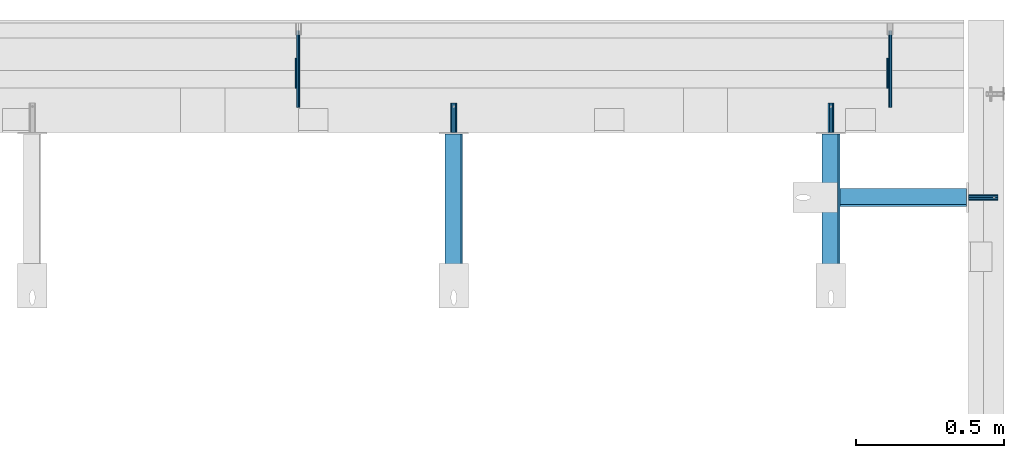
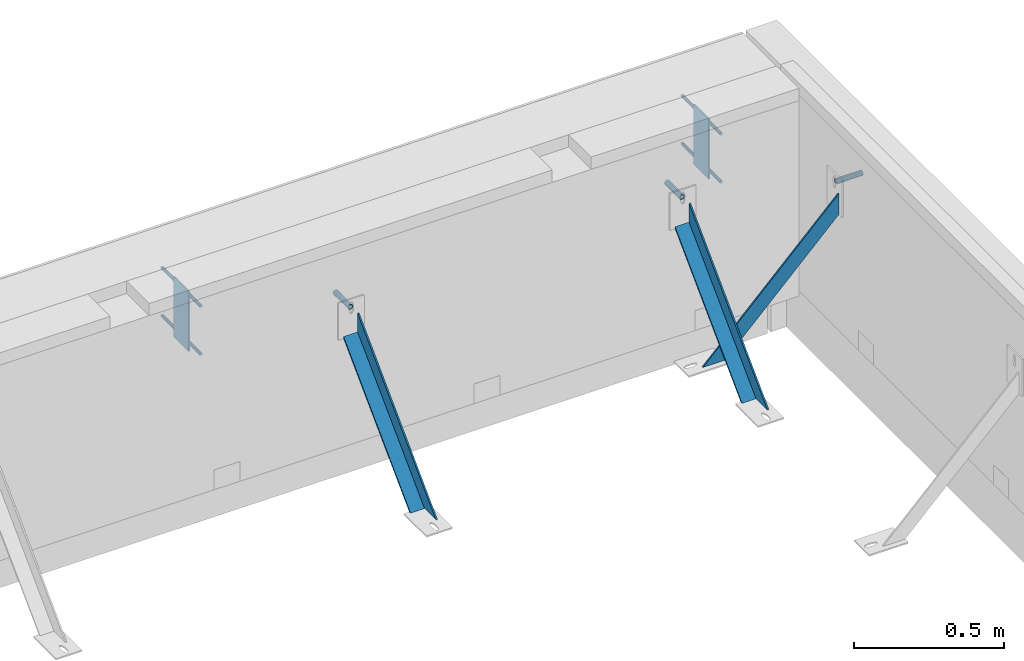
# One storey, part 58 of 153: 9 beams, 3 members, 14 elements without a shape of their own.
"""IFC2X3 building model written with IfcOpenShell, lengths in millimetres."""

from ifc_helpers import new_model, si_unit, frame, origin_with_axes, place, context, subcontext, project, spatial, faceted_brep, material, type_object, element, aggregate, save


model = new_model("IFC2X3")

# Units and contexts
model_context = context("Model", 3, precision=1e-05, world=origin_with_axes())
body_context = subcontext(model_context, "Body", "Model", "MODEL_VIEW")
ifc_project = project(units=[si_unit("LENGTHUNIT", "METRE", prefix="MILLI"), si_unit("AREAUNIT", "SQUARE_METRE"), si_unit("VOLUMEUNIT", "CUBIC_METRE"), si_unit("MASSUNIT", "GRAM", prefix="KILO"), si_unit("TIMEUNIT", "SECOND"), si_unit("PLANEANGLEUNIT", "RADIAN"), si_unit("SOLIDANGLEUNIT", "STERADIAN"), si_unit("THERMODYNAMICTEMPERATUREUNIT", "DEGREE_CELSIUS"), si_unit("LUMINOUSINTENSITYUNIT", "LUMEN")], contexts=[model_context])

# Site, building, storey
site_placement = place(None, origin_with_axes())
site = spatial("IfcSite", under=ifc_project, at=site_placement, CompositionType="ELEMENT")
building_placement = place(site_placement, origin_with_axes())
building = spatial("IfcBuilding", under=site, at=building_placement, CompositionType="ELEMENT")
storey_placement = place(building_placement, origin_with_axes())
storey = spatial("IfcBuildingStorey", under=building, at=storey_placement, Name="8", CompositionType="ELEMENT", Elevation=0.0)

# Assemblies, beam
assembly_1_placement = place(storey_placement, origin_with_axes())
assembly_1 = element("IfcElementAssembly", 1, at=assembly_1_placement, inside=storey, AssemblyPlace="NOTDEFINED", PredefinedType="REINFORCEMENT_UNIT")
assembly_2_placement = place(assembly_1_placement, origin_with_axes())
assembly_2 = element("IfcElementAssembly", 2, at=assembly_2_placement, Name="Steel Assembly", AssemblyPlace="NOTDEFINED", PredefinedType="RIGID_FRAME")
aggregate(assembly_1, [assembly_2])
ifc_material_1 = material(Name="STEEL/Steel_Undefined")
beam_type_1 = type_object("IfcBeamType", PredefinedType="NOTDEFINED")
beam_1_placement = place(assembly_2_placement, frame((35244.9969543136, 22400.0099999998, 103320.0), z_axis=(0.0, 1.0, 0.0), x_axis=(1.0, 0.0, 0.0)))
beam_1 = element("IfcBeam", 3, at=beam_1_placement, type_object=beam_type_1, material=ifc_material_1, Name="1036-G", context=body_context, shape_type="Brep", body=[
    faceted_brep([(0.0, -8.49999999999272, -1.45519152283669e-11), (0.0, -7.36121593215648, 4.24999999998545), (100.000000000262, -7.36121593215648, 4.24999999998545), (100.000000000262, -8.49999999999272, -1.45519152283669e-11), (0.0, -4.24999999998545, 7.36121593216376), (100.000000000262, -4.24999999998545, 7.36121593216376), (0.0, 1.45519152283669e-11, 8.49999999998545), (100.000000000262, 1.45519152283669e-11, 8.49999999998545), (0.0, 4.25000000001455, 7.36121593216376), (100.000000000262, 4.25000000001455, 7.36121593216376), (0.0, 7.36121593217104, 4.24999999998545), (100.000000000262, 7.36121593217104, 4.24999999998545), (0.0, 8.50000000000728, 0.0), (100.000000000262, 8.50000000000728, 0.0), (0.0, 7.36121593217104, -4.25000000001455), (100.000000000262, 7.36121593217104, -4.25000000001455), (0.0, 4.25000000000728, -7.36121593219286), (100.000000000262, 4.25000000000728, -7.36121593219286), (0.0, 7.27595761418343e-12, -8.5), (100.000000000262, 7.27595761418343e-12, -8.5), (0.0, -4.24999999999272, -7.36121593217831), (100.000000000262, -4.24999999999272, -7.36121593217831), (0.0, -7.36121593215648, -4.25), (100.000000000262, -7.36121593215648, -4.25), (0.0, -10.4999999999927, -1.45519152283669e-11), (0.0, -9.09326673972828, -5.25000000001455), (100.000000000262, -9.09326673972828, -5.25000000001455), (100.000000000262, -10.4999999999927, -1.45519152283669e-11), (0.0, -5.24999999998545, -9.09326673974283), (100.000000000262, -5.24999999998545, -9.09326673974283), (0.0, 7.27595761418343e-12, -10.5), (100.000000000262, 7.27595761418343e-12, -10.5), (0.0, 5.25000000001455, -9.09326673975738), (100.000000000262, 5.25000000001455, -9.09326673975738), (0.0, 9.09326673975011, -5.25000000001455), (100.000000000262, 9.09326673975011, -5.25000000001455), (0.0, 10.5000000000073, -1.45519152283669e-11), (100.000000000262, 10.5000000000073, -1.45519152283669e-11), (0.0, 9.09326673975011, 5.25), (100.000000000262, 9.09326673975011, 5.25), (0.0, 5.25000000000728, 9.09326673972828), (100.000000000262, 5.25000000000728, 9.09326673972828), (0.0, 1.45519152283669e-11, 10.4999999999854), (100.000000000262, 1.45519152283669e-11, 10.4999999999854), (0.0, -5.24999999999272, 9.09326673972828), (100.000000000262, -5.24999999999272, 9.09326673972828), (0.0, -9.09326673972828, 5.24999999998545), (100.000000000262, -9.09326673972828, 5.24999999998545)], [[[0, 1, 2, 3]], [[1, 4, 5, 2]], [[4, 6, 7, 5]], [[6, 8, 9, 7]], [[8, 10, 11, 9]], [[10, 12, 13, 11]], [[12, 14, 15, 13]], [[14, 16, 17, 15]], [[16, 18, 19, 17]], [[18, 20, 21, 19]], [[20, 22, 23, 21]], [[22, 0, 3, 23]], [[24, 25, 26, 27]], [[25, 28, 29, 26]], [[28, 30, 31, 29]], [[30, 32, 33, 31]], [[32, 34, 35, 33]], [[34, 36, 37, 35]], [[36, 38, 39, 37]], [[38, 40, 41, 39]], [[40, 42, 43, 41]], [[42, 44, 45, 43]], [[44, 46, 47, 45]], [[46, 24, 27, 47]], [[29, 31, 33, 35, 37, 39, 41, 43, 45, 47, 27, 26], [5, 7, 9, 11, 13, 15, 17, 19, 21, 23, 3, 2]], [[46, 44, 42, 40, 38, 36, 34, 32, 30, 28, 25, 24], [22, 20, 18, 16, 14, 12, 10, 8, 6, 4, 1, 0]]]),
])
aggregate(assembly_2, [beam_1])

# Assemblies, beams
assembly_3_placement = place(storey_placement, origin_with_axes())
assembly_3 = element("IfcElementAssembly", 4, at=assembly_3_placement, inside=storey, AssemblyPlace="NOTDEFINED", PredefinedType="REINFORCEMENT_UNIT")
assembly_4_placement = place(assembly_3_placement, origin_with_axes())
assembly_4 = element("IfcElementAssembly", 5, at=assembly_4_placement, Name="Steel Assembly", AssemblyPlace="NOTDEFINED", PredefinedType="RIGID_FRAME")
beam_2_placement = place(assembly_4_placement, frame((34779.9964000166, 22619.9999999999, 103285.0), z_axis=(-1.0, 3.00000001838171e-08, 0.0), x_axis=(0.0, 1.0, 0.0)))
beam_2 = element("IfcBeam", 6, at=beam_2_placement, type_object=beam_type_1, material=ifc_material_1, Name="1036-G", context=body_context, shape_type="Brep", body=[
    faceted_brep([(0.0, -8.49999999999272, -1.45519152283669e-11), (0.0, -7.36121593215648, 4.24999999998545), (100.000000000262, -7.36121593215648, 4.24999999998545), (100.000000000262, -8.49999999999272, -1.45519152283669e-11), (0.0, -4.24999999998545, 7.36121593216376), (100.000000000262, -4.24999999998545, 7.36121593216376), (0.0, 1.45519152283669e-11, 8.49999999998545), (100.000000000262, 1.45519152283669e-11, 8.49999999998545), (0.0, 4.25000000001455, 7.36121593216376), (100.000000000262, 4.25000000001455, 7.36121593216376), (0.0, 7.36121593217104, 4.24999999998545), (100.000000000262, 7.36121593217104, 4.24999999998545), (0.0, 8.50000000000728, 0.0), (100.000000000262, 8.50000000000728, 0.0), (0.0, 7.36121593217104, -4.25000000001455), (100.000000000262, 7.36121593217104, -4.25000000001455), (0.0, 4.25000000000728, -7.36121593219286), (100.000000000262, 4.25000000000728, -7.36121593219286), (0.0, 7.27595761418343e-12, -8.5), (100.000000000262, 7.27595761418343e-12, -8.5), (0.0, -4.24999999999272, -7.36121593217831), (100.000000000262, -4.24999999999272, -7.36121593217831), (0.0, -7.36121593215648, -4.25), (100.000000000262, -7.36121593215648, -4.25), (0.0, -10.4999999999927, -1.45519152283669e-11), (0.0, -9.09326673972828, -5.25000000001455), (100.000000000262, -9.09326673972828, -5.25000000001455), (100.000000000262, -10.4999999999927, -1.45519152283669e-11), (0.0, -5.24999999998545, -9.09326673974283), (100.000000000262, -5.24999999998545, -9.09326673974283), (0.0, 7.27595761418343e-12, -10.5), (100.000000000262, 7.27595761418343e-12, -10.5), (0.0, 5.25000000001455, -9.09326673975738), (100.000000000262, 5.25000000001455, -9.09326673975738), (0.0, 9.09326673975011, -5.25000000001455), (100.000000000262, 9.09326673975011, -5.25000000001455), (0.0, 10.5000000000073, -1.45519152283669e-11), (100.000000000262, 10.5000000000073, -1.45519152283669e-11), (0.0, 9.09326673975011, 5.25), (100.000000000262, 9.09326673975011, 5.25), (0.0, 5.25000000000728, 9.09326673972828), (100.000000000262, 5.25000000000728, 9.09326673972828), (0.0, 1.45519152283669e-11, 10.4999999999854), (100.000000000262, 1.45519152283669e-11, 10.4999999999854), (0.0, -5.24999999999272, 9.09326673972828), (100.000000000262, -5.24999999999272, 9.09326673972828), (0.0, -9.09326673972828, 5.24999999998545), (100.000000000262, -9.09326673972828, 5.24999999998545)], [[[0, 1, 2, 3]], [[1, 4, 5, 2]], [[4, 6, 7, 5]], [[6, 8, 9, 7]], [[8, 10, 11, 9]], [[10, 12, 13, 11]], [[12, 14, 15, 13]], [[14, 16, 17, 15]], [[16, 18, 19, 17]], [[18, 20, 21, 19]], [[20, 22, 23, 21]], [[22, 0, 3, 23]], [[24, 25, 26, 27]], [[25, 28, 29, 26]], [[28, 30, 31, 29]], [[30, 32, 33, 31]], [[32, 34, 35, 33]], [[34, 36, 37, 35]], [[36, 38, 39, 37]], [[38, 40, 41, 39]], [[40, 42, 43, 41]], [[42, 44, 45, 43]], [[44, 46, 47, 45]], [[46, 24, 27, 47]], [[29, 31, 33, 35, 37, 39, 41, 43, 45, 47, 27, 26], [5, 7, 9, 11, 13, 15, 17, 19, 21, 23, 3, 2]], [[46, 44, 42, 40, 38, 36, 34, 32, 30, 28, 25, 24], [22, 20, 18, 16, 14, 12, 10, 8, 6, 4, 1, 0]]]),
])
aggregate(assembly_4, [beam_2])
assembly_5_placement = place(assembly_3_placement, origin_with_axes())
assembly_5 = element("IfcElementAssembly", 7, at=assembly_5_placement, Name="Steel Assembly", AssemblyPlace="NOTDEFINED", PredefinedType="RIGID_FRAME")
beam_3_placement = place(assembly_5_placement, frame((33504.9999728033, 22619.9999999999, 103285.0), z_axis=(-1.0, 3.00000001838171e-08, 0.0), x_axis=(0.0, 1.0, 0.0)))
beam_3 = element("IfcBeam", 8, at=beam_3_placement, type_object=beam_type_1, material=ifc_material_1, Name="1036-G", context=body_context, shape_type="Brep", body=[
    faceted_brep([(0.0, -8.49999999999272, -1.45519152283669e-11), (0.0, -7.36121593215648, 4.24999999998545), (100.000000000262, -7.36121593215648, 4.24999999998545), (100.000000000262, -8.49999999999272, -1.45519152283669e-11), (0.0, -4.24999999998545, 7.36121593216376), (100.000000000262, -4.24999999998545, 7.36121593216376), (0.0, 1.45519152283669e-11, 8.49999999998545), (100.000000000262, 1.45519152283669e-11, 8.49999999998545), (0.0, 4.25000000001455, 7.36121593216376), (100.000000000262, 4.25000000001455, 7.36121593216376), (0.0, 7.36121593217104, 4.24999999998545), (100.000000000262, 7.36121593217104, 4.24999999998545), (0.0, 8.50000000000728, 0.0), (100.000000000262, 8.50000000000728, 0.0), (0.0, 7.36121593217104, -4.25000000001455), (100.000000000262, 7.36121593217104, -4.25000000001455), (0.0, 4.25000000000728, -7.36121593219286), (100.000000000262, 4.25000000000728, -7.36121593219286), (0.0, 7.27595761418343e-12, -8.5), (100.000000000262, 7.27595761418343e-12, -8.5), (0.0, -4.24999999999272, -7.36121593217831), (100.000000000262, -4.24999999999272, -7.36121593217831), (0.0, -7.36121593215648, -4.25), (100.000000000262, -7.36121593215648, -4.25), (0.0, -10.4999999999927, -1.45519152283669e-11), (0.0, -9.09326673972828, -5.25000000001455), (100.000000000262, -9.09326673972828, -5.25000000001455), (100.000000000262, -10.4999999999927, -1.45519152283669e-11), (0.0, -5.24999999998545, -9.09326673974283), (100.000000000262, -5.24999999998545, -9.09326673974283), (0.0, 7.27595761418343e-12, -10.5), (100.000000000262, 7.27595761418343e-12, -10.5), (0.0, 5.25000000001455, -9.09326673975738), (100.000000000262, 5.25000000001455, -9.09326673975738), (0.0, 9.09326673975011, -5.25000000001455), (100.000000000262, 9.09326673975011, -5.25000000001455), (0.0, 10.5000000000073, -1.45519152283669e-11), (100.000000000262, 10.5000000000073, -1.45519152283669e-11), (0.0, 9.09326673975011, 5.25), (100.000000000262, 9.09326673975011, 5.25), (0.0, 5.25000000000728, 9.09326673972828), (100.000000000262, 5.25000000000728, 9.09326673972828), (0.0, 1.45519152283669e-11, 10.4999999999854), (100.000000000262, 1.45519152283669e-11, 10.4999999999854), (0.0, -5.24999999999272, 9.09326673972828), (100.000000000262, -5.24999999999272, 9.09326673972828), (0.0, -9.09326673972828, 5.24999999998545), (100.000000000262, -9.09326673972828, 5.24999999998545)], [[[0, 1, 2, 3]], [[1, 4, 5, 2]], [[4, 6, 7, 5]], [[6, 8, 9, 7]], [[8, 10, 11, 9]], [[10, 12, 13, 11]], [[12, 14, 15, 13]], [[14, 16, 17, 15]], [[16, 18, 19, 17]], [[18, 20, 21, 19]], [[20, 22, 23, 21]], [[22, 0, 3, 23]], [[24, 25, 26, 27]], [[25, 28, 29, 26]], [[28, 30, 31, 29]], [[30, 32, 33, 31]], [[32, 34, 35, 33]], [[34, 36, 37, 35]], [[36, 38, 39, 37]], [[38, 40, 41, 39]], [[40, 42, 43, 41]], [[42, 44, 45, 43]], [[44, 46, 47, 45]], [[46, 24, 27, 47]], [[29, 31, 33, 35, 37, 39, 41, 43, 45, 47, 27, 26], [5, 7, 9, 11, 13, 15, 17, 19, 21, 23, 3, 2]], [[46, 44, 42, 40, 38, 36, 34, 32, 30, 28, 25, 24], [22, 20, 18, 16, 14, 12, 10, 8, 6, 4, 1, 0]]]),
])
aggregate(assembly_5, [beam_3])
assembly_6_placement = place(assembly_3_placement, origin_with_axes())
assembly_6 = element("IfcElementAssembly", 9, at=assembly_6_placement, Name="Steel Assembly", AssemblyPlace="NOTDEFINED", PredefinedType="RIGID_FRAME")
beam_type_2 = type_object("IfcBeamType", Name="D12", PredefinedType="NOTDEFINED")
beam_4_placement = place(assembly_6_placement, frame((32979.9934191889, 22704.9948219476, 103224.99266456), z_axis=(-1.0, 3.00000001838171e-08, 0.0), x_axis=(-1.71000001528888e-07, 0.999999999916793, 1.28990000076059e-05)))
beam_4 = element("IfcBeam", 10, at=beam_4_placement, type_object=beam_type_2, material=ifc_material_1, Name="M12", ObjectType="D12", context=body_context, shape_type="Brep", body=[
    faceted_brep([(0.0, -6.0, -1.45519152283669e-11), (0.0, -4.24264068712, -4.24264068713819), (260.003353918641, -4.24264068710909, -4.24264068711909), (260.003353918641, -6.0, 0.0), (3.63797880709171e-12, 0.0, -6.0000000000291), (260.003353918644, 0.0, -6.0), (0.0, 4.24264068712, -4.24264068713819), (260.003353918641, 4.24264068710909, -4.24264068711909), (0.0, 6.0, -1.45519152283669e-11), (260.003353918644, 6.0, 9.09494701772928e-13), (0.0, 4.24264068712, 4.24264068709454), (260.003353918641, 4.24264068710909, 4.24264068711909), (0.0, 0.0, 5.99999999998545), (260.003353918644, 0.0, 6.0), (0.0, -4.24264068712, 4.24264068709454), (260.003353918641, -4.24264068710909, 4.24264068711909)], [[[0, 1, 2, 3]], [[1, 4, 5, 2]], [[4, 6, 7, 5]], [[6, 8, 9, 7]], [[8, 10, 11, 9]], [[10, 12, 13, 11]], [[12, 14, 15, 13]], [[14, 0, 3, 15]], [[5, 7, 9, 11, 13, 15, 3, 2]], [[14, 12, 10, 8, 6, 4, 1, 0]]]),
])
aggregate(assembly_6, [beam_4])
assembly_7_placement = place(assembly_3_placement, origin_with_axes())
assembly_7 = element("IfcElementAssembly", 11, at=assembly_7_placement, Name="Steel Assembly", AssemblyPlace="NOTDEFINED", PredefinedType="RIGID_FRAME")
beam_5_placement = place(assembly_7_placement, frame((32979.9934191889, 22704.9948219476, 103419.99266456), z_axis=(-1.0, 3.00000001838171e-08, 0.0), x_axis=(-1.71000001528888e-07, 0.999999999916793, 1.28990000076059e-05)))
beam_5 = element("IfcBeam", 12, at=beam_5_placement, type_object=beam_type_2, material=ifc_material_1, Name="M12", ObjectType="D12", context=body_context, shape_type="Brep", body=[
    faceted_brep([(0.0, -6.0, -1.45519152283669e-11), (0.0, -4.24264068712, -4.24264068713819), (260.003353918641, -4.24264068710909, -4.24264068711909), (260.003353918641, -6.0, 0.0), (3.63797880709171e-12, 0.0, -6.0000000000291), (260.003353918644, 0.0, -6.0), (0.0, 4.24264068712, -4.24264068713819), (260.003353918641, 4.24264068710909, -4.24264068711909), (0.0, 6.0, -1.45519152283669e-11), (260.003353918644, 6.0, 9.09494701772928e-13), (0.0, 4.24264068712, 4.24264068709454), (260.003353918641, 4.24264068710909, 4.24264068711909), (0.0, 0.0, 5.99999999998545), (260.003353918644, 0.0, 6.0), (0.0, -4.24264068712, 4.24264068709454), (260.003353918641, -4.24264068710909, 4.24264068711909)], [[[0, 1, 2, 3]], [[1, 4, 5, 2]], [[4, 6, 7, 5]], [[6, 8, 9, 7]], [[8, 10, 11, 9]], [[10, 12, 13, 11]], [[12, 14, 15, 13]], [[14, 0, 3, 15]], [[5, 7, 9, 11, 13, 15, 3, 2]], [[14, 12, 10, 8, 6, 4, 1, 0]]]),
])
aggregate(assembly_7, [beam_5])
assembly_8_placement = place(assembly_3_placement, origin_with_axes())
assembly_8 = element("IfcElementAssembly", 13, at=assembly_8_placement, Name="Steel Assembly", AssemblyPlace="NOTDEFINED", PredefinedType="RIGID_FRAME")
beam_6_placement = place(assembly_8_placement, frame((34979.9934191889, 22704.9948219476, 103224.99266456), z_axis=(-1.0, 3.00000001838171e-08, 0.0), x_axis=(-1.71000001528888e-07, 0.999999999916793, 1.28990000076059e-05)))
beam_6 = element("IfcBeam", 14, at=beam_6_placement, type_object=beam_type_2, material=ifc_material_1, Name="M12", ObjectType="D12", context=body_context, shape_type="Brep", body=[
    faceted_brep([(0.0, -6.0, -1.45519152283669e-11), (0.0, -4.24264068712, -4.24264068713819), (260.003353918641, -4.24264068710909, -4.24264068711909), (260.003353918641, -6.0, 0.0), (3.63797880709171e-12, 0.0, -6.0000000000291), (260.003353918644, 0.0, -6.0), (0.0, 4.24264068712, -4.24264068713819), (260.003353918641, 4.24264068710909, -4.24264068711909), (0.0, 6.0, -1.45519152283669e-11), (260.003353918644, 6.0, 9.09494701772928e-13), (0.0, 4.24264068712, 4.24264068709454), (260.003353918641, 4.24264068710909, 4.24264068711909), (0.0, 0.0, 5.99999999998545), (260.003353918644, 0.0, 6.0), (0.0, -4.24264068712, 4.24264068709454), (260.003353918641, -4.24264068710909, 4.24264068711909)], [[[0, 1, 2, 3]], [[1, 4, 5, 2]], [[4, 6, 7, 5]], [[6, 8, 9, 7]], [[8, 10, 11, 9]], [[10, 12, 13, 11]], [[12, 14, 15, 13]], [[14, 0, 3, 15]], [[5, 7, 9, 11, 13, 15, 3, 2]], [[14, 12, 10, 8, 6, 4, 1, 0]]]),
])
aggregate(assembly_8, [beam_6])
assembly_9_placement = place(assembly_3_placement, origin_with_axes())
assembly_9 = element("IfcElementAssembly", 15, at=assembly_9_placement, Name="Steel Assembly", AssemblyPlace="NOTDEFINED", PredefinedType="RIGID_FRAME")
beam_7_placement = place(assembly_9_placement, frame((34979.9934191889, 22704.9948219476, 103419.99266456), z_axis=(-1.0, 3.00000001838171e-08, 0.0), x_axis=(-1.71000001528888e-07, 0.999999999916793, 1.28990000076059e-05)))
beam_7 = element("IfcBeam", 16, at=beam_7_placement, type_object=beam_type_2, material=ifc_material_1, Name="M12", ObjectType="D12", context=body_context, shape_type="Brep", body=[
    faceted_brep([(0.0, -6.0, -1.45519152283669e-11), (0.0, -4.24264068712, -4.24264068713819), (260.003353918641, -4.24264068710909, -4.24264068711909), (260.003353918641, -6.0, 0.0), (3.63797880709171e-12, 0.0, -6.0000000000291), (260.003353918644, 0.0, -6.0), (0.0, 4.24264068712, -4.24264068713819), (260.003353918641, 4.24264068710909, -4.24264068711909), (0.0, 6.0, -1.45519152283669e-11), (260.003353918644, 6.0, 9.09494701772928e-13), (0.0, 4.24264068712, 4.24264068709454), (260.003353918641, 4.24264068710909, 4.24264068711909), (0.0, 0.0, 5.99999999998545), (260.003353918644, 0.0, 6.0), (0.0, -4.24264068712, 4.24264068709454), (260.003353918641, -4.24264068710909, 4.24264068711909)], [[[0, 1, 2, 3]], [[1, 4, 5, 2]], [[4, 6, 7, 5]], [[6, 8, 9, 7]], [[8, 10, 11, 9]], [[10, 12, 13, 11]], [[12, 14, 15, 13]], [[14, 0, 3, 15]], [[5, 7, 9, 11, 13, 15, 3, 2]], [[14, 12, 10, 8, 6, 4, 1, 0]]]),
])
aggregate(assembly_9, [beam_7])
assembly_10_placement = place(assembly_3_placement, origin_with_axes())
assembly_10 = element("IfcElementAssembly", 17, at=assembly_10_placement, Name="Steel Assembly", AssemblyPlace="NOTDEFINED", PredefinedType="RIGID_FRAME")
ifc_material_2 = material(Name="STEEL/1.4301")
beam_type_3 = type_object("IfcBeamType", PredefinedType="NOTDEFINED")
beam_8_placement = place(assembly_10_placement, frame((32971.494772816, 22819.9981743288, 103444.99266456), z_axis=(0.0, 1.0, 0.0), x_axis=(0.0, 0.0, -1.0)))
beam_8 = element("IfcBeam", 18, at=beam_8_placement, type_object=beam_type_3, material=ifc_material_2, Name="RST", context=body_context, shape_type="Brep", body=[
    faceted_brep([(0.0, 2.5, -49.9999999999964), (0.0, 2.49999999999909, 50.0000000000036), (245.0, 2.49999999999909, 50.0000000000036), (245.0, 2.5, -49.9999999999964), (0.0, -2.50000000000091, 50.0000000000036), (245.0, -2.50000000000091, 50.0000000000036), (0.0, -2.50000000000091, -49.9999999999964), (245.0, -2.50000000000091, -49.9999999999964)], [[[0, 1, 2, 3]], [[1, 4, 5, 2]], [[4, 6, 7, 5]], [[6, 0, 3, 7]], [[5, 7, 3, 2]], [[6, 4, 1, 0]]]),
])
aggregate(assembly_10, [beam_8])
assembly_11_placement = place(assembly_3_placement, origin_with_axes())
assembly_11 = element("IfcElementAssembly", 19, at=assembly_11_placement, Name="Steel Assembly", AssemblyPlace="NOTDEFINED", PredefinedType="RIGID_FRAME")
aggregate(assembly_3, [assembly_4, assembly_5, assembly_6, assembly_10, assembly_7, assembly_8, assembly_11, assembly_9])
beam_9_placement = place(assembly_11_placement, frame((34971.494772816, 22819.9981743288, 103444.99266456), z_axis=(0.0, 1.0, 0.0), x_axis=(0.0, 0.0, -1.0)))
beam_9 = element("IfcBeam", 20, at=beam_9_placement, type_object=beam_type_3, material=ifc_material_2, Name="RST", context=body_context, shape_type="Brep", body=[
    faceted_brep([(0.0, 2.5, -49.9999999999964), (0.0, 2.49999999999909, 50.0000000000036), (245.0, 2.49999999999909, 50.0000000000036), (245.0, 2.5, -49.9999999999964), (0.0, -2.50000000000091, 50.0000000000036), (245.0, -2.50000000000091, 50.0000000000036), (0.0, -2.50000000000091, -49.9999999999964), (245.0, -2.50000000000091, -49.9999999999964)], [[[0, 1, 2, 3]], [[1, 4, 5, 2]], [[4, 6, 7, 5]], [[6, 0, 3, 7]], [[5, 7, 3, 2]], [[6, 4, 1, 0]]]),
])
aggregate(assembly_11, [beam_9])

# Assembly, member
assembly_12_placement = place(storey_placement, origin_with_axes())
assembly_12 = element("IfcElementAssembly", 21, at=assembly_12_placement, inside=storey, Name="Steel Assembly", AssemblyPlace="NOTDEFINED", PredefinedType="RIGID_FRAME")
ifc_material_3 = material(Name="STEEL/S355J2")
member_type = type_object("IfcMemberType", PredefinedType="NOTDEFINED")
member_1_placement = place(assembly_12_placement, frame((35260.2401975569, 22400.0100000009, 103268.816878981), z_axis=(-0.708108108195998, 0.0, 0.706104034195447), x_axis=(-0.706104034195442, 0.0, -0.708108108196003)))
member_1 = element("IfcMember", 22, at=member_1_placement, type_object=member_type, material=ifc_material_3, Name="2", context=body_context, shape_type="Brep", body=[
    faceted_brep([(60.1702928045706, 30.0, -30.0), (-5.28234522789717e-09, 30.0, 30.0), (739.999999918371, 30.0, 30.0000000000146), (680.169810768777, 30.0, -30.0), (-5.28234522789717e-09, 24.0, 30.0), (739.999999918371, 24.0, 30.0000000000146), (54.1532635235926, 24.0, -24.0), (686.152829683742, 24.0, -23.9999999999854), (54.1532635235926, -30.0, -24.0), (686.152829683742, -30.0, -23.9999999999854), (60.1702928045706, -30.0, -30.0), (680.169810768777, -30.0, -30.0)], [[[0, 1, 2, 3]], [[1, 4, 5, 2]], [[4, 6, 7, 5]], [[6, 8, 9, 7]], [[8, 10, 11, 9]], [[10, 0, 3, 11]], [[5, 7, 9, 11, 3, 2]], [[10, 8, 6, 4, 1, 0]]]),
])
aggregate(assembly_12, [member_1])

assembly_13_placement = place(storey_placement, origin_with_axes())
assembly_13 = element("IfcElementAssembly", 23, at=assembly_13_placement, inside=storey, Name="Steel Assembly", AssemblyPlace="NOTDEFINED", PredefinedType="RIGID_FRAME")
member_2_placement = place(assembly_13_placement, frame((34779.9964000167, 22635.2432432443, 103233.816878982), z_axis=(0.0, -0.708108108195998, 0.706104034195447), x_axis=(0.0, -0.706104034195442, -0.708108108196003)))
member_2 = element("IfcMember", 24, at=member_2_placement, type_object=member_type, material=ifc_material_3, Name="2", context=body_context, shape_type="Brep", body=[
    faceted_brep([(60.1702928045706, 30.0, -30.0), (-5.28234522789717e-09, 30.0, 30.0), (739.999999918371, 30.0, 30.0000000000146), (680.169810768777, 30.0, -30.0), (-5.28234522789717e-09, 24.0, 30.0), (739.999999918371, 24.0, 30.0000000000146), (54.1532635235926, 24.0, -24.0), (686.152829683742, 24.0, -23.9999999999854), (54.1532635235926, -30.0, -24.0), (686.152829683742, -30.0, -23.9999999999854), (60.1702928045706, -30.0, -30.0), (680.169810768777, -30.0, -30.0)], [[[0, 1, 2, 3]], [[1, 4, 5, 2]], [[4, 6, 7, 5]], [[6, 8, 9, 7]], [[8, 10, 11, 9]], [[10, 0, 3, 11]], [[5, 7, 9, 11, 3, 2]], [[10, 8, 6, 4, 1, 0]]]),
])
aggregate(assembly_13, [member_2])

assembly_14_placement = place(storey_placement, origin_with_axes())
assembly_14 = element("IfcElementAssembly", 25, at=assembly_14_placement, inside=storey, Name="Steel Assembly", AssemblyPlace="NOTDEFINED", PredefinedType="RIGID_FRAME")
member_3_placement = place(assembly_14_placement, frame((33504.9999728033, 22635.2432432443, 103233.816878982), z_axis=(0.0, -0.708108108195998, 0.706104034195447), x_axis=(0.0, -0.706104034195442, -0.708108108196003)))
member_3 = element("IfcMember", 26, at=member_3_placement, type_object=member_type, material=ifc_material_3, Name="2", context=body_context, shape_type="Brep", body=[
    faceted_brep([(60.1702928045706, 30.0, -30.0), (-5.28234522789717e-09, 30.0, 30.0), (739.999999918371, 30.0, 30.0000000000146), (680.169810768777, 30.0, -30.0), (-5.28234522789717e-09, 24.0, 30.0), (739.999999918371, 24.0, 30.0000000000146), (54.1532635235926, 24.0, -24.0), (686.152829683742, 24.0, -23.9999999999854), (54.1532635235926, -30.0, -24.0), (686.152829683742, -30.0, -23.9999999999854), (60.1702928045706, -30.0, -30.0), (680.169810768777, -30.0, -30.0)], [[[0, 1, 2, 3]], [[1, 4, 5, 2]], [[4, 6, 7, 5]], [[6, 8, 9, 7]], [[8, 10, 11, 9]], [[10, 0, 3, 11]], [[5, 7, 9, 11, 3, 2]], [[10, 8, 6, 4, 1, 0]]]),
])
aggregate(assembly_14, [member_3])

save(model, "model.ifc")
